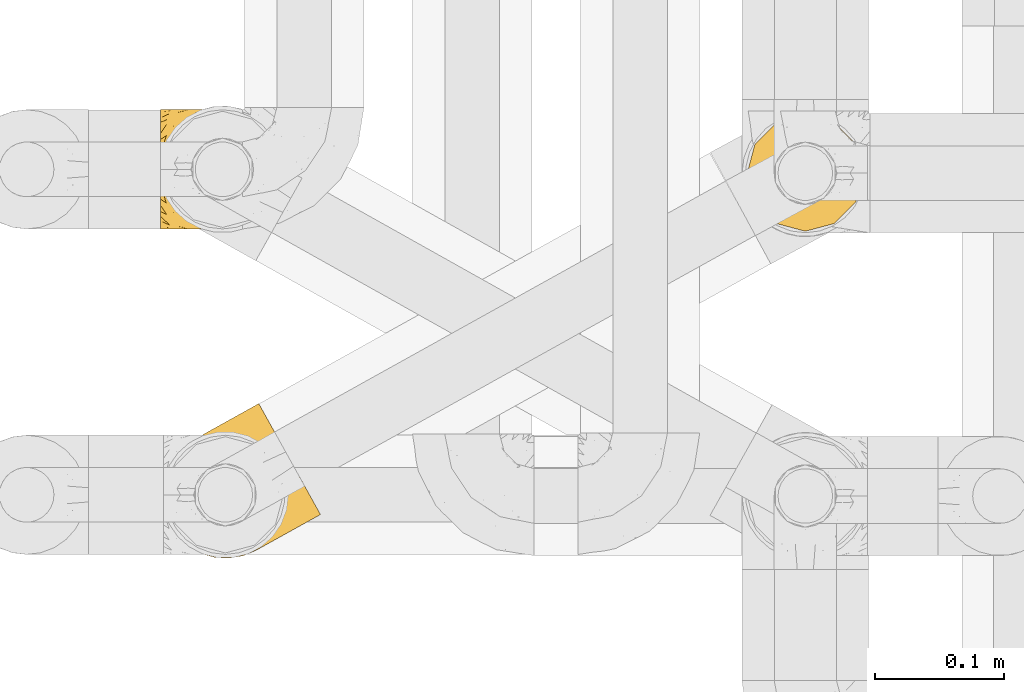
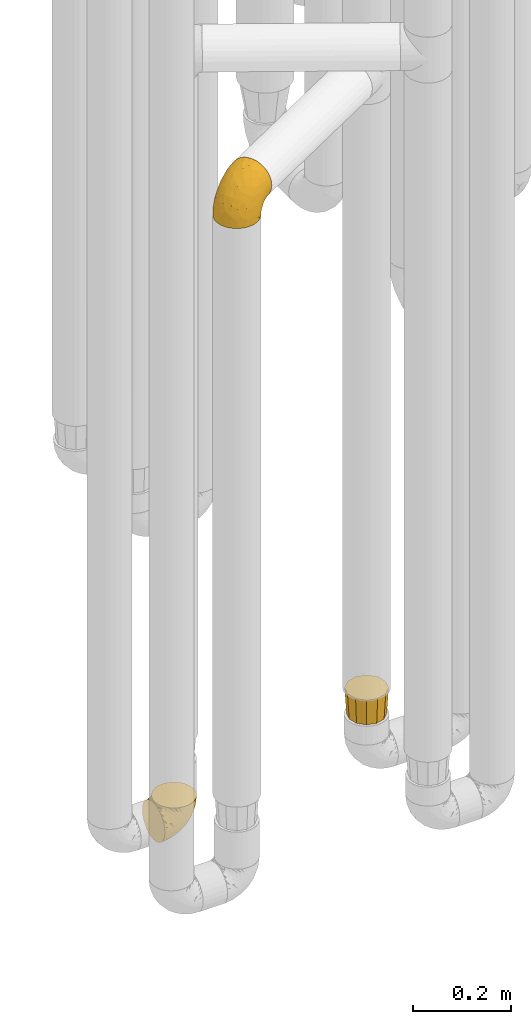
# One storey, part 151 of 827: 3 coverings.
"""IFC2X3 building model written with IfcOpenShell, lengths in millimetres."""

from ifc_helpers import new_model, entity, si_unit, converted_unit, derived_unit, direction, frame, origin, place, context, subcontext, project, spatial, faceted_brep, element, save


model = new_model("IFC2X3")

# Units and contexts
model_context = context("Model", 3, precision=0.01, world=origin(), true_north=direction((6.12303176911189e-17, 1.0)))
body_context = subcontext(model_context, "Body", "Model", "MODEL_VIEW")
ifc_project = project(units=[si_unit("LENGTHUNIT", "METRE", prefix="MILLI"), si_unit("AREAUNIT", "SQUARE_METRE"), si_unit("VOLUMEUNIT", "CUBIC_METRE"), converted_unit("PLANEANGLEUNIT", "DEGREE", entity("IfcRatioMeasure", 0.0174532925199433), si_unit("PLANEANGLEUNIT", "RADIAN"), dimensions=[0, 0, 0, 0, 0, 0, 0]), si_unit("MASSUNIT", "GRAM", prefix="KILO"), derived_unit("MASSDENSITYUNIT", [(si_unit("MASSUNIT", "GRAM", prefix="KILO"), 1), (si_unit("LENGTHUNIT", "METRE"), -3)]), derived_unit("MOMENTOFINERTIAUNIT", [(si_unit("LENGTHUNIT", "METRE"), 4)]), si_unit("TIMEUNIT", "SECOND"), si_unit("FREQUENCYUNIT", "HERTZ"), si_unit("THERMODYNAMICTEMPERATUREUNIT", "DEGREE_CELSIUS"), derived_unit("THERMALTRANSMITTANCEUNIT", [(si_unit("MASSUNIT", "GRAM", prefix="KILO"), 1), (si_unit("THERMODYNAMICTEMPERATUREUNIT", "KELVIN"), -1), (si_unit("TIMEUNIT", "SECOND"), -3)]), derived_unit("VOLUMETRICFLOWRATEUNIT", [(si_unit("LENGTHUNIT", "METRE"), 3), (si_unit("TIMEUNIT", "SECOND"), -1)]), derived_unit("MASSFLOWRATEUNIT", [(si_unit("MASSUNIT", "GRAM", prefix="KILO"), 1), (si_unit("TIMEUNIT", "SECOND"), -1)]), derived_unit("ROTATIONALFREQUENCYUNIT", [(si_unit("TIMEUNIT", "SECOND"), -1)]), si_unit("ELECTRICCURRENTUNIT", "AMPERE"), si_unit("ELECTRICVOLTAGEUNIT", "VOLT"), si_unit("POWERUNIT", "WATT"), si_unit("FORCEUNIT", "NEWTON", prefix="KILO"), si_unit("ILLUMINANCEUNIT", "LUX"), si_unit("LUMINOUSFLUXUNIT", "LUMEN"), si_unit("LUMINOUSINTENSITYUNIT", "CANDELA"), derived_unit("USERDEFINED", [(si_unit("MASSUNIT", "GRAM", prefix="KILO"), -1), (si_unit("LENGTHUNIT", "METRE"), -2), (si_unit("TIMEUNIT", "SECOND"), 3), (si_unit("LUMINOUSFLUXUNIT", "LUMEN"), 1)]), derived_unit("LINEARVELOCITYUNIT", [(si_unit("LENGTHUNIT", "METRE"), 1), (si_unit("TIMEUNIT", "SECOND"), -1)]), si_unit("PRESSUREUNIT", "PASCAL"), derived_unit("USERDEFINED", [(si_unit("LENGTHUNIT", "METRE"), -2), (si_unit("MASSUNIT", "GRAM", prefix="KILO"), 1), (si_unit("TIMEUNIT", "SECOND"), -2)]), derived_unit("LINEARFORCEUNIT", [(si_unit("MASSUNIT", "GRAM", prefix="KILO"), 1), (si_unit("LENGTHUNIT", "METRE"), 1), (si_unit("TIMEUNIT", "SECOND"), -2), (si_unit("LENGTHUNIT", "METRE"), -1)]), derived_unit("PLANARFORCEUNIT", [(si_unit("MASSUNIT", "GRAM", prefix="KILO"), 1), (si_unit("LENGTHUNIT", "METRE"), 1), (si_unit("TIMEUNIT", "SECOND"), -2), (si_unit("LENGTHUNIT", "METRE"), -2)])], contexts=[model_context])

# Site, building, storey
site_placement = place(None, origin())
site = spatial("IfcSite", under=ifc_project, at=site_placement, CompositionType="ELEMENT")
building_placement = place(site_placement, origin())
building = spatial("IfcBuilding", under=site, at=building_placement, CompositionType="ELEMENT")
storey_placement = place(building_placement, frame((0.0, 0.0, 28200.0)))
storey = spatial("IfcBuildingStorey", under=building, at=storey_placement, Name="08", CompositionType="ELEMENT", Elevation=28200.0)

# Coverings
covering_1_placement = place(storey_placement, frame((35228.21, 10306.43, 2041.4)))
element("IfcCovering", 1, at=covering_1_placement, inside=storey, Name=":ADSK_", ObjectType=":ADSK_", PredefinedType="INSULATION", context=body_context, shape_type="Brep", body=[
    faceted_brep([(74.55, 7.71, 1.6), (64.39, 3.47, 1.6), (53.54, 1.6, 1.6), (42.55, 2.18, 1.6), (31.97, 5.2, 1.6), (22.32, 10.5, 1.6), (14.1, 17.81, 1.6), (7.71, 26.77, 1.6), (3.47, 36.93, 1.6), (1.6, 47.78, 1.6), (2.18, 58.77, 1.6), (5.2, 69.35, 1.6), (10.5, 79.0, 1.6), (17.81, 87.22, 1.6), (26.77, 93.61, 1.6), (32.06, 95.82, 1.6), (36.93, 97.85, 1.6), (42.36, 98.79, 1.6), (47.78, 99.73, 1.6), (58.77, 99.14, 1.6), (69.35, 96.12, 1.6), (79.0, 90.82, 1.6), (87.22, 83.51, 1.6), (93.61, 74.55, 1.6), (97.85, 64.39, 1.6), (99.73, 53.54, 1.6), (99.14, 42.55, 1.6), (96.12, 31.97, 1.6), (90.82, 22.32, 1.6), (87.16, 18.21, 1.6), (83.51, 14.1, 1.6), (79.22, 11.04, 1.6), (76.89, 9.37, 1.6), (94.29, 89.49, 11.12), (88.53, 99.84, 16.03), (86.05, 104.29, 19.94), (83.58, 108.74, 23.84), (81.68, 112.15, 28.93), (79.78, 115.57, 34.02), (78.59, 117.71, 39.95), (77.4, 119.86, 45.87), (76.95, 120.66, 52.86), (76.76, 120.99, 55.73), (76.58, 121.32, 58.6), (77.4, 119.86, 71.32), (79.78, 115.57, 83.17), (83.58, 108.74, 93.35), (88.53, 99.84, 101.16), (94.29, 89.49, 106.07), (100.47, 78.37, 107.75), (106.66, 67.25, 106.07), (112.42, 56.89, 101.16), (117.37, 48.0, 93.35), (121.16, 41.17, 83.17), (123.55, 36.88, 71.32), (124.37, 35.42, 58.6), (124.0, 36.08, 52.86), (123.55, 36.88, 45.87), (122.36, 39.03, 39.95), (121.16, 41.17, 34.02), (119.27, 44.58, 28.93), (117.37, 48.0, 23.84), (114.89, 52.44, 19.94), (112.42, 56.89, 16.03), (106.66, 67.25, 11.12), (100.47, 78.37, 9.45), (44.89, 37.66, 81.82), (60.65, 30.67, 84.02), (62.77, 42.55, 93.05), (71.81, 62.42, 102.55), (85.28, 60.88, 104.83), (89.91, 72.49, 105.83), (78.21, 36.24, 91.87), (87.16, 51.58, 101.74), (97.93, 44.71, 97.07), (59.84, 5.91, 38.45), (67.64, 5.16, 22.17), (74.74, 9.53, 42.04), (102.4, 29.3, 77.69), (80.27, 22.31, 75.76), (83.33, 16.68, 62.11), (106.72, 26.87, 66.08), (105.3, 24.81, 54.26), (110.1, 27.48, 55.35), (114.89, 30.15, 56.44), (117.26, 31.46, 56.98), (119.63, 32.78, 57.52), (96.25, 34.18, 87.84), (56.75, 2.71, 19.41), (23.08, 24.23, 48.89), (19.28, 16.62, 26.34), (31.45, 14.66, 44.55), (78.34, 9.82, 23.41), (81.04, 11.32, 28.03), (83.74, 12.82, 32.65), (86.44, 14.32, 37.28), (89.14, 15.82, 41.9), (46.84, 2.88, 20.6), (32.77, 26.52, 63.36), (69.8, 14.22, 62.21), (26.83, 9.36, 19.94), (9.38, 27.7, 13.68), (70.32, 25.62, 80.85), (60.01, 16.57, 66.53), (52.06, 21.48, 71.06), (25.42, 36.62, 63.99), (35.69, 42.33, 75.73), (36.95, 6.11, 26.77), (75.02, 7.97, 4.31), (75.49, 8.23, 7.01), (76.44, 8.76, 12.43), (77.39, 9.29, 17.92), (48.48, 7.81, 43.43), (46.28, 13.77, 56.23), (90.94, 17.66, 54.97), (12.25, 29.29, 34.4), (93.18, 18.07, 44.99), (97.22, 20.32, 48.08), (101.26, 22.57, 51.17), (45.95, 48.04, 87.47), (44.92, 28.17, 74.55), (39.24, 19.7, 60.86), (18.84, 32.96, 49.19), (58.88, 55.23, 95.01), (84.13, 14.42, 10.27), (117.67, 32.7, 48.79), (109.25, 28.27, 45.16), (114.77, 31.92, 44.99), (100.2, 57.89, 6.17), (100.83, 48.73, 7.65), (87.97, 16.73, 21.59), (84.04, 13.67, 19.96), (110.88, 46.6, 21.0), (112.59, 40.8, 27.2), (107.06, 53.4, 14.83), (106.74, 42.82, 19.7), (102.7, 50.84, 10.93), (102.25, 63.3, 9.63), (100.85, 32.71, 19.97), (96.58, 26.0, 21.13), (97.94, 31.62, 14.14), (115.62, 40.52, 30.2), (97.17, 33.16, 8.12), (99.93, 39.89, 9.93), (103.73, 33.26, 24.62), (89.1, 19.27, 11.87), (95.62, 75.67, 7.15), (97.75, 67.44, 5.32), (91.13, 18.67, 26.68), (102.03, 41.28, 13.92), (96.83, 22.82, 30.67), (112.5, 33.79, 36.65), (105.14, 26.02, 42.89), (108.17, 31.72, 34.04), (100.71, 24.38, 36.6), (107.96, 36.86, 26.41), (93.6, 25.61, 10.07), (94.63, 25.44, 15.83), (101.0, 23.32, 41.99), (82.74, 97.13, 14.83), (69.17, 106.62, 26.4), (78.98, 103.98, 21.01), (73.6, 102.44, 19.71), (80.53, 90.51, 5.72), (41.5, 100.25, 21.6), (36.84, 98.53, 19.96), (33.26, 97.22, 28.03), (44.29, 99.88, 11.87), (67.52, 98.2, 9.93), (74.21, 120.0, 58.06), (67.11, 116.05, 56.44), (71.84, 118.69, 57.52), (60.35, 99.4, 8.13), (59.43, 100.87, 14.15), (68.55, 115.02, 44.99), (68.94, 112.1, 36.65), (74.94, 108.48, 27.21), (64.9, 109.51, 34.04), (76.3, 111.2, 30.2), (52.07, 100.35, 10.06), (52.44, 101.32, 15.83), (70.74, 117.06, 48.79), (58.46, 109.94, 42.89), (62.33, 112.2, 45.38), (28.65, 94.66, 12.43), (37.53, 98.22, 10.28), (88.61, 87.83, 9.64), (62.31, 113.38, 55.35), (57.52, 110.72, 54.26), (87.35, 84.98, 6.05), (27.71, 94.14, 7.01), (28.18, 94.4, 9.72), (35.96, 98.73, 32.65), (44.83, 101.91, 26.68), (69.8, 99.25, 13.92), (38.66, 100.23, 37.28), (51.4, 104.58, 30.66), (53.93, 102.69, 21.14), (54.73, 107.04, 36.59), (63.9, 104.92, 24.6), (29.61, 95.19, 17.92), (30.56, 95.72, 23.41), (78.27, 94.77, 10.93), (61.9, 102.77, 19.97), (53.98, 107.84, 41.99), (49.44, 106.22, 48.08), (53.48, 108.47, 51.17), (45.4, 103.98, 44.99), (41.36, 101.73, 41.9), (43.64, 102.08, 55.26), (77.6, 74.68, 104.83), (60.7, 98.09, 87.84), (42.46, 90.94, 75.91), (39.78, 80.62, 80.84), (52.94, 81.67, 91.87), (38.9, 69.72, 83.98), (12.98, 80.97, 19.16), (20.78, 88.92, 22.37), (60.01, 110.83, 66.08), (50.16, 65.22, 93.05), (70.69, 81.18, 101.74), (70.53, 93.96, 97.07), (59.8, 105.89, 77.69), (9.94, 53.34, 44.55), (5.18, 41.96, 26.34), (13.66, 41.18, 48.9), (26.54, 67.21, 70.99), (28.53, 57.64, 74.55), (17.29, 82.02, 37.8), (36.57, 52.62, 81.82), (5.58, 62.53, 26.77), (8.06, 72.63, 20.6), (16.95, 66.3, 56.15), (18.33, 57.25, 60.85), (28.39, 92.79, 42.06), (26.01, 84.51, 57.03), (20.75, 48.17, 63.4), (3.01, 52.21, 19.94), (13.19, 71.47, 43.59), (38.72, 95.84, 62.61), (26.62, 76.6, 66.52)], [[[0, 1, 2, 3, 4, 5, 6, 7, 8, 9, 10, 11, 12, 13, 14, 15, 16, 17, 18, 19, 20, 21, 22, 23, 24, 25, 26, 27, 28, 29, 30, 31, 32]], [[33, 34, 35, 36, 37, 38, 39, 40, 41, 42, 43, 44, 45, 46, 47, 48, 49, 50, 51, 52, 53, 54, 55, 56, 57, 58, 59, 60, 61, 62, 63, 64, 65]], [[66, 67, 68]], [[69, 70, 71]], [[68, 72, 73]], [[73, 72, 74]], [[75, 76, 77]], [[78, 79, 80]], [[51, 50, 73]], [[81, 82, 83, 84, 85, 86, 55]], [[52, 87, 53]], [[74, 52, 51]], [[2, 1, 88]], [[89, 90, 91]], [[77, 92, 93, 94, 95, 96]], [[55, 54, 81]], [[78, 53, 87]], [[5, 90, 6]], [[88, 76, 75]], [[97, 3, 2]], [[89, 91, 98]], [[99, 80, 79]], [[90, 5, 100]], [[74, 87, 52]], [[100, 5, 4]], [[90, 101, 6]], [[79, 102, 103]], [[102, 67, 104]], [[105, 98, 106]], [[107, 4, 3]], [[76, 0, 108, 109, 110, 111, 92]], [[107, 112, 113]], [[114, 77, 96]], [[89, 115, 90]], [[114, 96, 116, 117, 118, 82]], [[75, 97, 88]], [[119, 66, 68]], [[50, 71, 70]], [[100, 91, 90]], [[99, 77, 80]], [[102, 104, 103]], [[97, 107, 3]], [[80, 81, 78]], [[107, 97, 112]], [[68, 73, 70]], [[66, 98, 120]], [[78, 81, 54]], [[114, 81, 80]], [[53, 78, 54]], [[78, 87, 79]], [[102, 87, 72]], [[79, 103, 99]], [[4, 107, 100]], [[91, 100, 107]], [[88, 97, 2]], [[112, 97, 75]], [[99, 112, 75]], [[103, 104, 113]], [[91, 121, 98]], [[89, 105, 122, 115]], [[101, 90, 115]], [[101, 7, 6]], [[88, 1, 76]], [[0, 76, 1]], [[92, 77, 76]], [[73, 74, 51]], [[87, 74, 72]], [[81, 114, 82]], [[77, 114, 80]], [[87, 102, 79]], [[67, 102, 72]], [[68, 67, 72]], [[67, 120, 104]], [[120, 121, 104]], [[104, 121, 113]], [[121, 120, 98]], [[91, 107, 113]], [[91, 113, 121]], [[103, 113, 112]], [[106, 98, 66]], [[105, 89, 98]], [[106, 66, 119]], [[67, 66, 120]], [[68, 69, 123, 119]], [[50, 49, 71]], [[50, 70, 73]], [[112, 99, 103]], [[77, 99, 75]], [[69, 68, 70]], [[29, 124, 110]], [[84, 83, 125]], [[126, 82, 118]], [[59, 58, 127]], [[25, 128, 129]], [[130, 93, 131]], [[132, 62, 133]], [[134, 135, 136]], [[137, 65, 64]], [[64, 134, 137]], [[138, 139, 140]], [[111, 110, 124, 92]], [[134, 136, 137]], [[134, 64, 63]], [[141, 61, 60]], [[125, 58, 57]], [[142, 143, 140]], [[142, 26, 143]], [[127, 83, 82]], [[28, 124, 29]], [[108, 0, 32, 31, 30, 110, 109]], [[30, 29, 110]], [[135, 144, 138]], [[28, 145, 124]], [[57, 56, 55, 86, 85, 84]], [[146, 147, 23]], [[24, 23, 147]], [[25, 143, 26]], [[95, 94, 148]], [[24, 128, 25]], [[149, 138, 143]], [[124, 145, 131]], [[127, 58, 125]], [[150, 148, 139]], [[127, 126, 151]], [[151, 59, 127]], [[152, 151, 126]], [[153, 154, 155]], [[153, 133, 141]], [[145, 28, 27]], [[142, 156, 27]], [[157, 148, 130]], [[61, 133, 62]], [[134, 132, 135]], [[147, 128, 24]], [[65, 137, 146]], [[146, 137, 147]], [[128, 137, 136]], [[137, 128, 147]], [[128, 136, 129]], [[149, 129, 136]], [[25, 129, 143]], [[158, 152, 117]], [[152, 118, 117]], [[153, 151, 152]], [[158, 116, 154]], [[144, 150, 138]], [[153, 152, 158]], [[133, 153, 155]], [[133, 155, 132]], [[60, 151, 141]], [[135, 132, 155]], [[134, 63, 132]], [[144, 135, 155]], [[135, 138, 149]], [[155, 154, 144]], [[150, 154, 96]], [[154, 150, 144]], [[148, 94, 130]], [[82, 126, 127]], [[118, 152, 126]], [[150, 96, 95]], [[139, 148, 157]], [[150, 95, 148]], [[93, 92, 131]], [[130, 145, 156]], [[130, 94, 93]], [[84, 125, 57]], [[127, 125, 83]], [[140, 139, 157]], [[150, 139, 138]], [[140, 157, 142]], [[138, 140, 143]], [[156, 142, 157]], [[27, 26, 142]], [[130, 156, 157]], [[145, 27, 156]], [[132, 63, 62]], [[124, 131, 92]], [[130, 131, 145]], [[129, 149, 143]], [[135, 149, 136]], [[141, 133, 61]], [[60, 59, 151]], [[141, 151, 153]], [[116, 96, 154]], [[153, 158, 154]], [[158, 117, 116]], [[34, 33, 159]], [[160, 161, 162]], [[22, 21, 163]], [[164, 165, 166]], [[19, 18, 167]], [[168, 21, 20]], [[169, 43, 42, 41, 40, 170, 171]], [[172, 173, 168]], [[174, 38, 175]], [[176, 177, 178]], [[179, 164, 180]], [[40, 181, 170]], [[182, 183, 175]], [[17, 184, 185]], [[65, 146, 186]], [[187, 174, 188]], [[23, 22, 189]], [[174, 39, 38]], [[15, 14, 190, 191, 184, 16]], [[181, 40, 39]], [[192, 193, 164]], [[194, 163, 168]], [[33, 186, 159]], [[180, 173, 172]], [[195, 196, 193]], [[18, 185, 167]], [[173, 180, 197]], [[198, 199, 196]], [[200, 201, 185, 184]], [[184, 17, 16]], [[18, 17, 185]], [[202, 159, 186]], [[194, 168, 203]], [[189, 163, 202]], [[204, 205, 182]], [[187, 181, 174]], [[160, 177, 176]], [[206, 183, 182]], [[206, 182, 205]], [[201, 165, 185]], [[165, 164, 167]], [[172, 179, 180]], [[202, 194, 162]], [[176, 161, 160]], [[65, 186, 33]], [[163, 189, 22]], [[175, 177, 182]], [[174, 183, 188]], [[177, 198, 204]], [[199, 160, 162]], [[198, 207, 204]], [[175, 38, 37]], [[198, 177, 160]], [[178, 177, 175]], [[176, 35, 161]], [[34, 159, 161]], [[162, 161, 159]], [[202, 162, 159]], [[199, 162, 203]], [[196, 199, 203]], [[198, 160, 199]], [[193, 197, 180]], [[208, 198, 196]], [[188, 183, 206]], [[175, 183, 174]], [[193, 192, 195]], [[195, 208, 196]], [[197, 196, 203]], [[180, 164, 193]], [[168, 163, 21]], [[166, 165, 201]], [[166, 192, 164]], [[189, 202, 186]], [[186, 146, 189]], [[23, 189, 146]], [[174, 181, 39]], [[170, 181, 187]], [[196, 197, 193]], [[173, 203, 168]], [[203, 173, 197]], [[172, 168, 20]], [[20, 19, 172]], [[179, 172, 19]], [[19, 167, 179]], [[164, 179, 167]], [[35, 176, 36]], [[35, 34, 161]], [[185, 165, 167]], [[162, 194, 203]], [[163, 194, 202]], [[176, 178, 36]], [[37, 36, 178]], [[175, 37, 178]], [[177, 204, 182]], [[207, 198, 208]], [[207, 205, 204]], [[209, 188, 206, 205, 207, 208]], [[48, 210, 71]], [[211, 212, 213]], [[214, 213, 215]], [[216, 217, 13]], [[218, 43, 169, 171, 170, 187, 188]], [[219, 220, 214]], [[47, 46, 221]], [[210, 48, 220]], [[211, 222, 212]], [[222, 45, 44]], [[221, 220, 47]], [[47, 220, 48]], [[221, 211, 214]], [[223, 224, 225]], [[211, 46, 45]], [[226, 227, 215]], [[43, 218, 44]], [[217, 216, 228]], [[215, 229, 219]], [[14, 13, 217]], [[224, 9, 8]], [[10, 230, 11]], [[11, 231, 12]], [[232, 223, 233]], [[234, 208, 195, 192, 166, 201]], [[235, 234, 228]], [[222, 44, 218]], [[106, 229, 236]], [[224, 237, 9]], [[231, 238, 228]], [[9, 237, 10]], [[115, 224, 101]], [[239, 234, 235]], [[231, 11, 230]], [[223, 230, 237]], [[224, 8, 101]], [[223, 236, 233]], [[225, 115, 122, 105]], [[216, 12, 231]], [[209, 234, 239]], [[210, 219, 69]], [[219, 214, 215]], [[229, 119, 219]], [[209, 218, 188]], [[239, 212, 222]], [[239, 222, 218]], [[45, 222, 211]], [[235, 212, 239]], [[213, 212, 240]], [[223, 237, 224]], [[230, 10, 237]], [[238, 231, 230]], [[216, 231, 228]], [[232, 230, 223]], [[235, 238, 240]], [[115, 225, 224]], [[233, 236, 227]], [[8, 7, 101]], [[234, 209, 208]], [[218, 209, 239]], [[217, 228, 234]], [[13, 12, 216]], [[234, 201, 217]], [[217, 201, 200, 184, 191, 190, 14]], [[211, 221, 46]], [[220, 221, 214]], [[71, 210, 69]], [[71, 49, 48]], [[219, 210, 220]], [[226, 215, 213]], [[211, 213, 214]], [[226, 213, 240]], [[215, 227, 229]], [[232, 240, 238]], [[233, 227, 226]], [[232, 233, 226]], [[236, 223, 225]], [[240, 232, 226]], [[232, 238, 230]], [[225, 105, 236]], [[236, 105, 106]], [[229, 106, 119]], [[69, 219, 119, 123]], [[236, 229, 227]], [[238, 235, 228]], [[212, 235, 240]]]),
])
covering_2_placement = place(storey_placement, frame((35681.45, 10559.61, 495.0)))
element("IfcCovering", 2, at=covering_2_placement, inside=storey, Name=":ADSK_", ObjectType=":ADSK_", PredefinedType="INSULATION", context=body_context, shape_type="Brep", body=[
    faceted_brep([(85.57, 24.1, 64.0), (88.01, 33.21, 64.0), (91.6, 46.6, 64.0), (88.01, 59.99, 64.0), (85.57, 69.1, 64.0), (77.33, 77.33, 64.0), (69.1, 85.57, 64.0), (59.99, 88.01, 64.0), (46.6, 91.6, 64.0), (33.21, 88.01, 64.0), (24.1, 85.57, 64.0), (15.86, 77.33, 64.0), (7.62, 69.1, 64.0), (5.18, 59.99, 64.0), (1.6, 46.6, 64.0), (5.18, 33.21, 64.0), (7.62, 24.1, 64.0), (15.86, 15.86, 64.0), (24.1, 7.62, 64.0), (33.21, 5.18, 64.0), (46.6, 1.6, 64.0), (59.99, 5.18, 64.0), (69.1, 7.62, 64.0), (77.33, 15.86, 64.0), (82.1, 26.1, 0.0), (74.6, 18.59, 0.0), (67.1, 11.09, 0.0), (56.85, 8.34, 0.0), (46.6, 5.6, 0.0), (36.35, 8.34, 0.0), (26.1, 11.09, 0.0), (18.59, 18.59, 0.0), (11.09, 26.1, 0.0), (8.34, 36.35, 0.0), (5.6, 46.6, 0.0), (8.34, 56.85, 0.0), (11.09, 67.1, 0.0), (18.59, 74.6, 0.0), (26.1, 82.1, 0.0), (36.35, 84.85, 0.0), (46.6, 87.6, 0.0), (56.85, 84.85, 0.0), (67.1, 82.1, 0.0), (74.6, 74.6, 0.0), (82.1, 67.1, 0.0), (84.85, 56.85, 0.0), (87.6, 46.6, 0.0), (84.85, 36.35, 0.0)], [[[0, 1, 2, 3, 4, 5, 6, 7, 8, 9, 10, 11, 12, 13, 14, 15, 16, 17, 18, 19, 20, 21, 22, 23]], [[24, 25, 26, 27, 28, 29, 30, 31, 32, 33, 34, 35, 36, 37, 38, 39, 40, 41, 42, 43, 44, 45, 46, 47]], [[38, 10, 9, 8, 40, 39]], [[11, 10, 38, 37, 36, 12]], [[35, 34, 14, 13, 12, 36]], [[32, 16, 15, 14, 34, 33]], [[17, 16, 32, 31, 30, 18]], [[29, 28, 20, 19, 18, 30]], [[26, 22, 21, 20, 28, 27]], [[23, 22, 26, 25, 24, 0]], [[47, 46, 2, 1, 0, 24]], [[44, 4, 3, 2, 46, 45]], [[5, 4, 44, 43, 42, 6]], [[41, 40, 8, 7, 6, 42]]]),
])
covering_3_placement = place(storey_placement, frame((35227.14, 10561.35, 352.2)))
element("IfcCovering", 3, at=covering_3_placement, inside=storey, Name=":ADSK_", ObjectType=":ADSK_", PredefinedType="INSULATION", context=body_context, shape_type="Brep", body=[
    faceted_brep([(78.41, 11.68, 95.8), (85.72, 19.0, 95.8), (91.22, 27.76, 95.8), (94.64, 37.52, 95.8), (95.8, 47.8, 95.8), (94.64, 58.08, 95.8), (91.22, 67.85, 95.8), (85.71, 76.61, 95.8), (78.39, 83.92, 95.8), (69.63, 89.42, 95.8), (59.87, 92.84, 95.8), (49.6, 94.0, 95.8), (45.45, 93.53, 95.8), (42.38, 93.18, 95.8), (39.31, 92.84, 95.8), (34.43, 91.13, 95.8), (29.54, 89.42, 95.8), (25.16, 86.66, 95.8), (20.78, 83.91, 95.8), (17.13, 80.25, 95.8), (13.47, 76.59, 95.8), (7.97, 67.83, 95.8), (6.26, 62.95, 95.8), (4.55, 58.07, 95.8), (3.4, 47.8, 95.8), (4.55, 37.51, 95.8), (6.26, 32.63, 95.8), (7.97, 27.74, 95.8), (13.48, 18.98, 95.8), (17.14, 15.33, 95.8), (20.8, 11.67, 95.8), (25.18, 8.92, 95.8), (29.56, 6.17, 95.8), (34.44, 4.46, 95.8), (39.32, 2.75, 95.8), (42.39, 2.41, 95.8), (45.45, 2.06, 95.8), (49.6, 1.6, 95.8), (59.88, 2.75, 95.8), (69.65, 6.17, 95.8), (1.6, 47.8, 94.0), (1.6, 59.75, 92.42), (1.6, 70.9, 87.81), (1.6, 75.68, 84.13), (1.6, 80.46, 80.46), (1.6, 84.13, 75.68), (1.6, 87.81, 70.9), (1.6, 90.11, 65.32), (1.6, 92.42, 59.75), (1.6, 92.9, 56.14), (1.6, 93.17, 54.06), (1.6, 93.45, 51.97), (1.6, 94.0, 47.8), (1.6, 92.42, 35.84), (1.6, 87.81, 24.7), (1.6, 80.46, 15.13), (1.6, 70.9, 7.78), (1.6, 59.75, 3.17), (1.6, 47.8, 1.6), (1.6, 35.84, 3.17), (1.6, 24.7, 7.78), (1.6, 15.13, 15.13), (1.6, 7.78, 24.7), (1.6, 3.17, 35.84), (1.6, 1.6, 47.8), (1.6, 2.14, 51.97), (1.6, 2.69, 56.14), (1.6, 3.17, 59.75), (1.6, 5.48, 65.32), (1.6, 7.78, 70.9), (1.6, 11.46, 75.68), (1.6, 15.13, 80.46), (1.6, 19.91, 84.13), (1.6, 24.7, 87.81), (1.6, 35.84, 92.42), (36.81, 23.61, 15.84), (23.28, 31.99, 6.99), (45.8, 35.87, 14.39), (30.7, 47.8, 6.21), (21.2, 40.43, 4.26), (12.96, 47.8, 3.39), (66.19, 31.83, 31.2), (54.51, 23.37, 26.47), (17.98, 21.41, 11.44), (36.69, 3.07, 47.66), (35.54, 1.6, 61.85), (31.64, 1.6, 59.25), (27.75, 1.6, 56.65), (23.86, 1.6, 54.05), (19.96, 1.6, 51.45), (22.8, 13.45, 19.8), (42.67, 15.25, 26.22), (33.21, 8.07, 31.58), (59.45, 16.0, 38.36), (71.5, 17.34, 51.54), (62.66, 10.58, 51.6), (54.5, 5.34, 55.97), (47.57, 2.39, 62.88), (48.81, 8.36, 41.35), (74.98, 10.04, 82.24), (18.7, 2.59, 40.88), (15.75, 6.28, 29.0), (91.17, 34.28, 74.06), (85.28, 38.73, 54.53), (82.58, 27.25, 57.98), (75.78, 29.88, 43.81), (74.98, 38.6, 38.22), (67.27, 23.44, 38.33), (87.38, 25.25, 74.76), (82.04, 17.23, 76.85), (94.0, 47.8, 84.43), (77.8, 47.8, 40.43), (67.38, 47.8, 30.01), (56.2, 2.53, 78.67), (48.85, 1.6, 92.06), (48.11, 1.6, 88.32), (47.57, 1.6, 85.6), (47.03, 1.6, 82.88), (46.48, 1.6, 80.15), (45.94, 1.6, 77.43), (65.78, 5.71, 76.36), (17.24, 1.6, 50.91), (14.51, 1.6, 50.37), (11.79, 1.6, 49.82), (9.07, 1.6, 49.28), (7.2, 1.6, 48.91), (5.33, 1.6, 48.54), (91.18, 47.8, 66.69), (43.34, 1.6, 73.53), (40.74, 1.6, 69.64), (38.14, 1.6, 65.75), (72.73, 11.89, 66.13), (56.96, 47.8, 19.59), (62.23, 39.69, 24.64), (84.49, 47.8, 53.56), (43.83, 47.8, 12.9), (12.05, 13.84, 82.81), (18.95, 9.16, 81.22), (13.02, 15.79, 86.57), (8.34, 25.75, 92.75), (14.63, 16.09, 89.68), (11.09, 7.51, 72.26), (13.66, 3.99, 64.73), (20.08, 2.66, 62.45), (9.61, 3.16, 60.63), (9.48, 2.35, 56.91), (16.1, 2.23, 58.14), (3.42, 38.35, 93.7), (26.63, 6.18, 83.4), (33.72, 2.7, 75.54), (34.77, 2.93, 79.46), (6.75, 16.01, 82.28), (13.31, 9.08, 76.25), (21.11, 9.3, 84.69), (19.94, 11.68, 90.18), (8.67, 4.65, 65.12), (26.11, 3.65, 71.71), (29.3, 3.61, 75.21), (6.32, 12.8, 78.6), (39.92, 2.43, 87.27), (27.05, 6.83, 87.92), (6.04, 21.65, 86.94), (34.4, 3.7, 86.1), (2.87, 47.8, 94.52), (20.92, 3.37, 66.23), (27.43, 7.03, 91.08), (7.54, 7.87, 71.77), (18.45, 7.26, 76.21), (23.88, 3.41, 68.59), (7.77, 23.81, 89.94), (13.3, 86.5, 76.25), (11.09, 88.08, 72.26), (6.33, 82.79, 78.6), (9.07, 94.0, 49.28), (5.33, 94.0, 48.54), (14.51, 94.0, 50.37), (11.79, 94.0, 49.82), (3.42, 57.24, 93.7), (7.76, 71.76, 89.95), (47.03, 94.0, 82.88), (47.57, 94.0, 85.6), (48.85, 94.0, 92.06), (48.11, 94.0, 88.32), (14.62, 79.49, 89.68), (27.03, 88.75, 87.92), (20.08, 92.93, 62.45), (20.92, 92.22, 66.24), (27.75, 94.0, 56.65), (31.64, 94.0, 59.25), (9.61, 92.43, 60.63), (9.48, 93.24, 56.91), (8.33, 69.82, 92.76), (6.74, 79.57, 82.28), (12.04, 81.74, 82.81), (23.86, 94.0, 54.05), (19.96, 94.0, 51.45), (16.1, 93.36, 58.14), (19.93, 83.9, 90.18), (21.1, 86.28, 84.7), (39.92, 93.16, 87.25), (33.68, 92.88, 75.58), (29.28, 91.98, 75.2), (26.62, 89.41, 83.39), (26.08, 91.93, 71.7), (18.93, 86.42, 81.22), (27.87, 88.82, 90.73), (34.75, 92.66, 79.47), (6.04, 73.93, 86.94), (38.14, 94.0, 65.75), (12.79, 79.5, 86.75), (34.41, 91.89, 86.08), (45.94, 94.0, 77.43), (43.34, 94.0, 73.53), (40.74, 94.0, 69.64), (13.66, 91.6, 64.73), (17.24, 94.0, 50.91), (8.67, 90.94, 65.12), (35.54, 94.0, 61.85), (23.83, 92.16, 68.62), (18.43, 88.32, 76.22), (6.03, 86.13, 74.03), (46.48, 94.0, 80.15), (34.52, 93.2, 49.81), (21.2, 55.16, 4.26), (23.82, 82.02, 19.95), (41.32, 84.29, 30.61), (47.62, 76.94, 25.71), (52.66, 68.33, 22.43), (36.81, 71.98, 15.85), (49.75, 92.52, 60.69), (19.07, 92.9, 40.49), (45.8, 59.72, 14.39), (23.28, 63.6, 6.99), (21.35, 88.89, 29.56), (17.98, 74.18, 11.45), (82.57, 68.35, 57.98), (91.17, 61.33, 74.06), (85.27, 56.86, 54.52), (73.89, 68.62, 43.47), (66.19, 63.76, 31.2), (62.43, 72.19, 33.27), (63.53, 88.69, 64.26), (58.45, 92.19, 74.29), (67.16, 89.75, 80.41), (62.22, 55.9, 24.64), (81.54, 77.99, 73.62), (74.8, 85.21, 78.98), (75.83, 74.99, 53.69), (41.45, 90.23, 42.86), (76.72, 59.86, 41.67), (88.2, 70.75, 79.66), (71.6, 81.72, 58.41), (56.23, 86.53, 47.11), (59.44, 79.6, 38.37)], [[[0, 1, 2, 3, 4, 5, 6, 7, 8, 9, 10, 11, 12, 13, 14, 15, 16, 17, 18, 19, 20, 21, 22, 23, 24, 25, 26, 27, 28, 29, 30, 31, 32, 33, 34, 35, 36, 37, 38, 39]], [[40, 41, 42, 43, 44, 45, 46, 47, 48, 49, 50, 51, 52, 53, 54, 55, 56, 57, 58, 59, 60, 61, 62, 63, 64, 65, 66, 67, 68, 69, 70, 71, 72, 73, 74]], [[75, 76, 77]], [[78, 79, 80]], [[77, 81, 82]], [[76, 75, 83]], [[84, 85, 86, 87, 88, 89]], [[90, 91, 92]], [[76, 60, 59]], [[93, 94, 95]], [[90, 62, 61]], [[83, 61, 60]], [[96, 97, 84]], [[98, 93, 95]], [[0, 39, 99]], [[100, 84, 89]], [[62, 101, 63]], [[2, 102, 3]], [[92, 84, 100]], [[103, 102, 104]], [[103, 105, 106]], [[93, 107, 94]], [[1, 108, 2]], [[92, 101, 90]], [[108, 1, 109]], [[102, 110, 3]], [[93, 82, 107]], [[102, 108, 104]], [[111, 106, 112]], [[109, 0, 99]], [[113, 37, 114, 115, 116, 117, 118, 119]], [[120, 38, 113]], [[100, 89, 121, 122, 123, 124, 125, 126, 64]], [[127, 102, 103]], [[97, 119, 128, 129, 130, 85]], [[99, 120, 131]], [[132, 133, 77]], [[59, 80, 79]], [[1, 0, 109]], [[98, 84, 92]], [[94, 109, 131]], [[120, 39, 38]], [[93, 91, 82]], [[104, 94, 105]], [[97, 113, 119]], [[95, 120, 96]], [[83, 90, 61]], [[91, 93, 98]], [[64, 63, 100]], [[100, 63, 101]], [[77, 76, 79]], [[133, 106, 81]], [[84, 97, 85]], [[113, 96, 120]], [[113, 97, 96]], [[37, 113, 38]], [[110, 102, 127]], [[110, 4, 3]], [[103, 111, 134, 127]], [[90, 75, 91]], [[82, 81, 107]], [[91, 75, 82]], [[77, 82, 75]], [[76, 83, 60]], [[90, 83, 75]], [[105, 107, 81]], [[94, 131, 95]], [[105, 94, 107]], [[109, 94, 104]], [[120, 95, 131]], [[98, 95, 96]], [[84, 98, 96]], [[98, 92, 91]], [[106, 105, 81]], [[103, 104, 105]], [[112, 106, 133]], [[103, 106, 111]], [[112, 133, 132]], [[81, 77, 133]], [[77, 78, 135, 132]], [[120, 99, 39]], [[109, 99, 131]], [[59, 58, 80]], [[59, 79, 76]], [[90, 101, 62]], [[100, 101, 92]], [[2, 108, 102]], [[109, 104, 108]], [[78, 77, 79]], [[136, 137, 138]], [[27, 139, 140]], [[141, 142, 143]], [[144, 145, 121]], [[146, 89, 88]], [[147, 139, 25]], [[148, 149, 150]], [[136, 151, 152]], [[147, 40, 74]], [[24, 147, 25]], [[140, 153, 154]], [[33, 116, 34]], [[73, 72, 151]], [[114, 37, 36, 35, 34, 116, 115]], [[146, 155, 144]], [[156, 85, 130]], [[157, 149, 148]], [[151, 158, 152]], [[117, 33, 159]], [[29, 154, 160]], [[161, 74, 73]], [[162, 128, 119]], [[66, 65, 64, 126, 125, 124, 123, 122, 67]], [[163, 147, 24]], [[27, 140, 28]], [[149, 129, 150]], [[139, 27, 26, 25]], [[68, 144, 69]], [[129, 128, 150]], [[164, 87, 86]], [[130, 129, 149]], [[122, 145, 67]], [[154, 153, 148]], [[162, 119, 159]], [[165, 30, 160]], [[150, 160, 148]], [[128, 162, 150]], [[30, 165, 31]], [[145, 144, 68]], [[89, 146, 144]], [[87, 164, 143]], [[166, 155, 142]], [[88, 87, 143]], [[162, 160, 150]], [[160, 30, 29]], [[154, 29, 28]], [[140, 154, 28]], [[160, 154, 148]], [[140, 137, 153]], [[157, 148, 153]], [[156, 130, 157]], [[153, 137, 157]], [[157, 137, 156]], [[167, 137, 136]], [[168, 85, 156]], [[152, 168, 167]], [[167, 168, 156]], [[164, 152, 141]], [[71, 158, 72]], [[152, 167, 136]], [[88, 142, 146]], [[144, 155, 69]], [[146, 142, 155]], [[70, 166, 71]], [[142, 141, 166]], [[70, 69, 155]], [[141, 158, 71]], [[161, 73, 151]], [[138, 137, 140]], [[161, 136, 169]], [[136, 161, 151]], [[74, 161, 169]], [[152, 158, 141]], [[151, 72, 158]], [[168, 152, 164]], [[137, 167, 156]], [[164, 86, 168]], [[85, 168, 86]], [[116, 33, 117]], [[130, 149, 157]], [[67, 145, 68]], [[121, 89, 144]], [[145, 122, 121]], [[40, 147, 163]], [[169, 147, 74]], [[159, 33, 32]], [[162, 159, 32]], [[159, 119, 118, 117]], [[139, 147, 169]], [[139, 169, 138]], [[162, 32, 31]], [[141, 143, 164]], [[88, 143, 142]], [[71, 166, 141]], [[155, 166, 70]], [[139, 138, 140]], [[169, 136, 138]], [[160, 162, 165]], [[162, 31, 165]], [[170, 171, 172]], [[173, 174, 52, 51, 50, 49, 48, 175, 176]], [[177, 178, 41]], [[179, 15, 180]], [[12, 11, 181, 182, 180, 14, 13]], [[183, 21, 20]], [[19, 18, 184]], [[185, 186, 187]], [[186, 188, 187]], [[43, 172, 44]], [[189, 190, 47]], [[23, 22, 21, 191]], [[170, 192, 193]], [[40, 163, 177]], [[194, 195, 196]], [[24, 23, 177]], [[197, 198, 183]], [[199, 15, 179]], [[47, 46, 189]], [[200, 201, 202]], [[201, 203, 204]], [[205, 206, 184]], [[207, 41, 178]], [[16, 15, 199]], [[14, 180, 15]], [[202, 201, 198]], [[208, 201, 200]], [[163, 24, 177]], [[48, 47, 190]], [[196, 195, 189]], [[197, 184, 202]], [[204, 193, 209]], [[210, 211, 212]], [[206, 212, 213]], [[205, 17, 210]], [[184, 206, 202]], [[210, 212, 206]], [[185, 194, 214]], [[189, 215, 190]], [[216, 45, 214]], [[186, 171, 170]], [[189, 216, 196]], [[197, 20, 19]], [[194, 185, 187]], [[197, 183, 20]], [[184, 197, 19]], [[197, 202, 198]], [[206, 200, 202]], [[204, 183, 198]], [[201, 208, 203]], [[203, 208, 217]], [[204, 198, 201]], [[217, 188, 218]], [[193, 219, 170]], [[171, 186, 185]], [[170, 218, 186]], [[170, 219, 218]], [[42, 207, 192]], [[171, 220, 172]], [[216, 189, 46]], [[214, 194, 196]], [[44, 220, 45]], [[214, 196, 216]], [[216, 46, 45]], [[214, 45, 220]], [[192, 43, 42]], [[204, 203, 219]], [[207, 193, 192]], [[209, 193, 178]], [[41, 207, 42]], [[193, 207, 178]], [[43, 192, 172]], [[170, 172, 192]], [[204, 219, 193]], [[219, 203, 218]], [[217, 218, 203]], [[188, 186, 218]], [[206, 213, 200]], [[208, 200, 213]], [[199, 210, 16]], [[215, 189, 195]], [[215, 175, 190]], [[175, 48, 190]], [[199, 179, 221, 211]], [[210, 199, 211]], [[23, 191, 177]], [[40, 177, 41]], [[178, 177, 191]], [[21, 183, 191]], [[209, 191, 183]], [[205, 18, 17]], [[17, 16, 210]], [[171, 185, 214]], [[172, 220, 44]], [[214, 220, 171]], [[191, 209, 178]], [[204, 209, 183]], [[206, 205, 210]], [[18, 205, 184]], [[222, 195, 194, 187, 188, 217]], [[57, 223, 80]], [[224, 225, 226]], [[226, 227, 228]], [[229, 217, 208, 213, 212, 211]], [[230, 52, 174, 173, 176, 175, 215, 195]], [[231, 232, 228]], [[231, 78, 223]], [[223, 57, 232]], [[224, 233, 225]], [[233, 54, 53]], [[234, 232, 56]], [[56, 55, 234]], [[234, 224, 228]], [[235, 236, 237]], [[224, 55, 54]], [[238, 239, 240]], [[52, 230, 53]], [[241, 242, 243]], [[227, 244, 231]], [[11, 10, 242]], [[236, 6, 5]], [[7, 245, 8]], [[8, 246, 9]], [[238, 247, 235]], [[222, 229, 248]], [[242, 211, 221, 179, 180, 182, 181, 11]], [[233, 53, 230]], [[111, 112, 249]], [[250, 6, 236]], [[246, 251, 241]], [[6, 250, 7]], [[127, 236, 110]], [[248, 229, 252]], [[246, 8, 245]], [[235, 245, 250]], [[236, 5, 110]], [[235, 249, 238]], [[237, 236, 127]], [[243, 9, 246]], [[252, 229, 241]], [[56, 232, 57]], [[222, 230, 195]], [[225, 248, 252]], [[248, 233, 230]], [[54, 233, 224]], [[231, 228, 227]], [[244, 132, 231]], [[248, 225, 233]], [[226, 225, 253]], [[235, 250, 236]], [[245, 7, 250]], [[251, 246, 245]], [[243, 246, 241]], [[247, 245, 235]], [[252, 251, 253]], [[229, 222, 217]], [[230, 222, 248]], [[5, 4, 110]], [[237, 127, 134, 111]], [[238, 249, 239]], [[224, 234, 55]], [[232, 234, 228]], [[242, 241, 229]], [[10, 9, 243]], [[211, 242, 229]], [[10, 243, 242]], [[80, 223, 78]], [[80, 58, 57]], [[231, 223, 232]], [[227, 240, 239]], [[224, 226, 228]], [[240, 226, 253]], [[227, 239, 244]], [[226, 240, 227]], [[251, 247, 253]], [[240, 253, 247]], [[249, 235, 237]], [[237, 111, 249]], [[112, 132, 244]], [[112, 244, 249]], [[78, 231, 132, 135]], [[249, 244, 239]], [[247, 238, 240]], [[245, 247, 251]], [[251, 252, 241]], [[225, 252, 253]]]),
])

save(model, "model.ifc")
